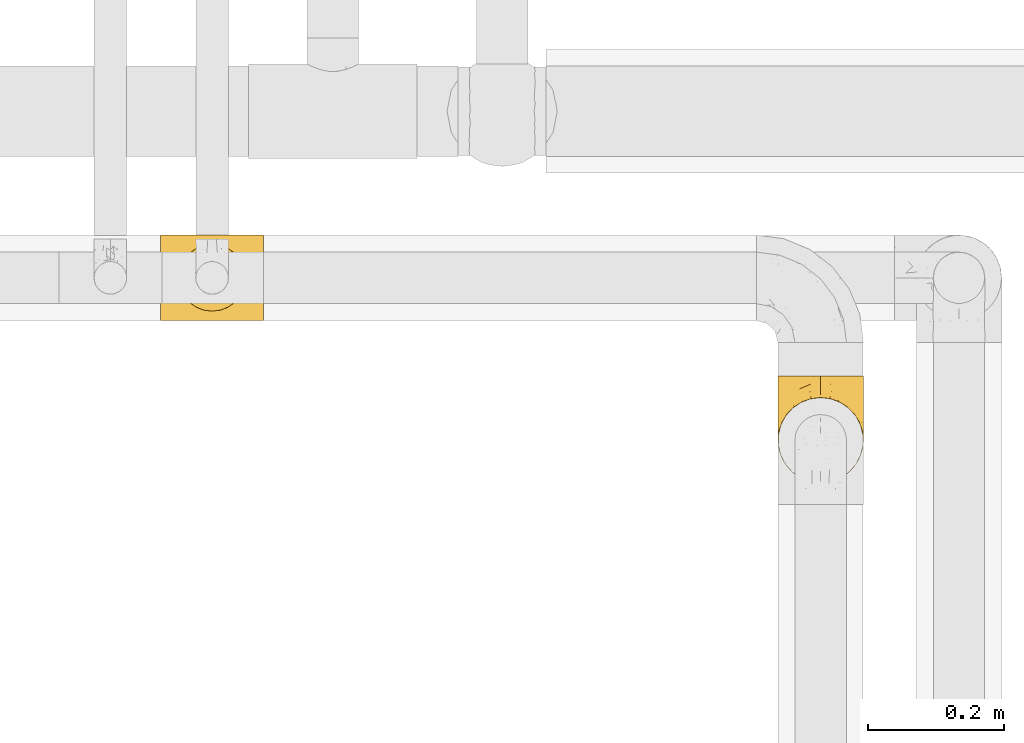
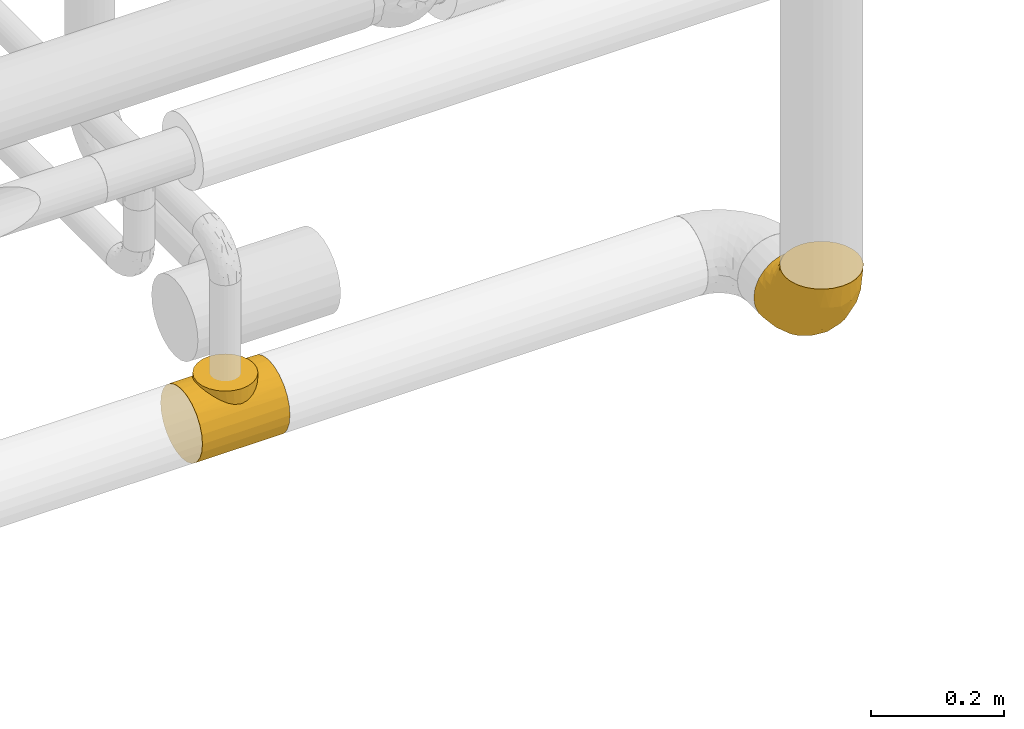
# One storey, part 121 of 827: 2 coverings.
"""IFC2X3 building model written with IfcOpenShell, lengths in millimetres."""

from ifc_helpers import new_model, entity, si_unit, converted_unit, derived_unit, direction, frame, origin, place, context, subcontext, project, spatial, faceted_brep, element, save


model = new_model("IFC2X3")

# Units and contexts
model_context = context("Model", 3, precision=0.01, world=origin(), true_north=direction((6.12303176911189e-17, 1.0)))
body_context = subcontext(model_context, "Body", "Model", "MODEL_VIEW")
ifc_project = project(units=[si_unit("LENGTHUNIT", "METRE", prefix="MILLI"), si_unit("AREAUNIT", "SQUARE_METRE"), si_unit("VOLUMEUNIT", "CUBIC_METRE"), converted_unit("PLANEANGLEUNIT", "DEGREE", entity("IfcRatioMeasure", 0.0174532925199433), si_unit("PLANEANGLEUNIT", "RADIAN"), dimensions=[0, 0, 0, 0, 0, 0, 0]), si_unit("MASSUNIT", "GRAM", prefix="KILO"), derived_unit("MASSDENSITYUNIT", [(si_unit("MASSUNIT", "GRAM", prefix="KILO"), 1), (si_unit("LENGTHUNIT", "METRE"), -3)]), derived_unit("MOMENTOFINERTIAUNIT", [(si_unit("LENGTHUNIT", "METRE"), 4)]), si_unit("TIMEUNIT", "SECOND"), si_unit("FREQUENCYUNIT", "HERTZ"), si_unit("THERMODYNAMICTEMPERATUREUNIT", "DEGREE_CELSIUS"), derived_unit("THERMALTRANSMITTANCEUNIT", [(si_unit("MASSUNIT", "GRAM", prefix="KILO"), 1), (si_unit("THERMODYNAMICTEMPERATUREUNIT", "KELVIN"), -1), (si_unit("TIMEUNIT", "SECOND"), -3)]), derived_unit("VOLUMETRICFLOWRATEUNIT", [(si_unit("LENGTHUNIT", "METRE"), 3), (si_unit("TIMEUNIT", "SECOND"), -1)]), derived_unit("MASSFLOWRATEUNIT", [(si_unit("MASSUNIT", "GRAM", prefix="KILO"), 1), (si_unit("TIMEUNIT", "SECOND"), -1)]), derived_unit("ROTATIONALFREQUENCYUNIT", [(si_unit("TIMEUNIT", "SECOND"), -1)]), si_unit("ELECTRICCURRENTUNIT", "AMPERE"), si_unit("ELECTRICVOLTAGEUNIT", "VOLT"), si_unit("POWERUNIT", "WATT"), si_unit("FORCEUNIT", "NEWTON", prefix="KILO"), si_unit("ILLUMINANCEUNIT", "LUX"), si_unit("LUMINOUSFLUXUNIT", "LUMEN"), si_unit("LUMINOUSINTENSITYUNIT", "CANDELA"), derived_unit("USERDEFINED", [(si_unit("MASSUNIT", "GRAM", prefix="KILO"), -1), (si_unit("LENGTHUNIT", "METRE"), -2), (si_unit("TIMEUNIT", "SECOND"), 3), (si_unit("LUMINOUSFLUXUNIT", "LUMEN"), 1)]), derived_unit("LINEARVELOCITYUNIT", [(si_unit("LENGTHUNIT", "METRE"), 1), (si_unit("TIMEUNIT", "SECOND"), -1)]), si_unit("PRESSUREUNIT", "PASCAL"), derived_unit("USERDEFINED", [(si_unit("LENGTHUNIT", "METRE"), -2), (si_unit("MASSUNIT", "GRAM", prefix="KILO"), 1), (si_unit("TIMEUNIT", "SECOND"), -2)]), derived_unit("LINEARFORCEUNIT", [(si_unit("MASSUNIT", "GRAM", prefix="KILO"), 1), (si_unit("LENGTHUNIT", "METRE"), 1), (si_unit("TIMEUNIT", "SECOND"), -2), (si_unit("LENGTHUNIT", "METRE"), -1)]), derived_unit("PLANARFORCEUNIT", [(si_unit("MASSUNIT", "GRAM", prefix="KILO"), 1), (si_unit("LENGTHUNIT", "METRE"), 1), (si_unit("TIMEUNIT", "SECOND"), -2), (si_unit("LENGTHUNIT", "METRE"), -2)])], contexts=[model_context])

# Site, building, storey
site_placement = place(None, origin())
site = spatial("IfcSite", under=ifc_project, at=site_placement, CompositionType="ELEMENT")
building_placement = place(site_placement, origin())
building = spatial("IfcBuilding", under=site, at=building_placement, CompositionType="ELEMENT")
storey_placement = place(building_placement, frame((0.0, 0.0, 28200.0)))
storey = spatial("IfcBuildingStorey", under=building, at=storey_placement, Name="08", CompositionType="ELEMENT", Elevation=28200.0)

# Coverings
covering_1_placement = place(storey_placement, frame((25690.21, 12005.36, 2535.35)))
element("IfcCovering", 1, at=covering_1_placement, inside=storey, Name=":ADSK_", ObjectType=":ADSK_", PredefinedType="INSULATION", context=body_context, shape_type="Brep", body=[
    faceted_brep([(152.0, 33.12, 10.04), (152.0, 48.33, 3.74), (152.0, 64.65, 1.6), (152.0, 80.96, 3.74), (152.0, 96.17, 10.04), (152.0, 109.23, 20.06), (152.0, 119.25, 33.12), (152.0, 125.55, 48.33), (152.0, 127.7, 64.65), (152.0, 125.55, 80.96), (152.0, 119.25, 96.17), (152.0, 109.23, 109.23), (152.0, 102.7, 114.24), (152.0, 96.17, 119.25), (152.0, 88.57, 122.4), (152.0, 80.96, 125.55), (152.0, 72.8, 126.62), (152.0, 64.65, 127.7), (152.0, 56.49, 126.62), (152.0, 48.33, 125.55), (152.0, 40.72, 122.4), (152.0, 33.12, 119.25), (152.0, 26.59, 114.24), (152.0, 20.06, 109.23), (152.0, 10.04, 96.17), (152.0, 3.74, 80.96), (152.0, 1.6, 64.65), (152.0, 3.74, 48.33), (152.0, 10.04, 33.12), (152.0, 20.06, 20.06), (0.0, 127.7, 64.65), (0.0, 125.55, 48.33), (0.0, 119.25, 33.12), (0.0, 109.23, 20.06), (0.0, 96.17, 10.04), (0.0, 80.96, 3.74), (0.0, 64.65, 1.6), (0.0, 48.33, 3.74), (0.0, 33.12, 10.04), (0.0, 20.06, 20.06), (0.0, 10.04, 33.12), (0.0, 3.74, 48.33), (0.0, 1.6, 64.65), (0.0, 3.74, 80.96), (0.0, 10.04, 96.17), (0.0, 20.06, 109.23), (0.0, 26.59, 114.24), (0.0, 33.12, 119.25), (0.0, 40.72, 122.4), (0.0, 48.33, 125.55), (0.0, 56.49, 126.62), (0.0, 64.65, 127.7), (0.0, 72.8, 126.62), (0.0, 80.96, 125.55), (0.0, 88.57, 122.4), (0.0, 96.17, 119.25), (0.0, 102.7, 114.24), (0.0, 109.23, 109.23), (0.0, 119.25, 96.17), (0.0, 125.55, 80.96), (45.43, 103.13, 114.58), (54.33, 108.76, 109.69), (37.94, 95.74, 119.49), (119.94, 86.67, 123.72), (64.61, 112.46, 105.75), (76.0, 113.8, 104.14), (87.39, 112.46, 105.75), (124.47, 70.38, 127.17), (125.15, 64.65, 127.7), (26.85, 64.65, 127.7), (27.53, 70.38, 127.17), (106.57, 103.13, 114.58), (97.67, 108.76, 109.69), (114.06, 95.74, 119.49), (32.06, 86.67, 123.72), (121.87, 81.39, 125.18), (123.79, 76.12, 126.64), (28.21, 76.12, 126.64), (30.13, 81.39, 125.18), (27.53, 58.91, 127.17), (28.21, 53.17, 126.64), (37.94, 33.55, 119.49), (32.06, 42.62, 123.72), (30.13, 47.9, 125.18), (123.79, 53.17, 126.64), (124.47, 58.91, 127.17), (114.06, 33.55, 119.49), (119.94, 42.62, 123.72), (106.57, 26.16, 114.58), (121.87, 47.9, 125.18), (45.43, 26.16, 114.58), (54.33, 20.53, 109.69), (64.61, 16.83, 105.75), (76.0, 15.5, 104.14), (97.67, 20.53, 109.69), (87.39, 16.83, 105.75), (63.28, 112.12, 131.65), (51.42, 107.21, 131.65), (41.25, 99.4, 131.65), (33.43, 89.22, 131.65), (30.98, 83.29, 131.65), (28.52, 77.37, 131.65), (27.69, 71.01, 131.65), (26.85, 64.65, 131.65), (27.69, 58.28, 131.65), (28.52, 51.92, 131.65), (30.98, 46.0, 131.65), (33.43, 40.07, 131.65), (41.25, 29.89, 131.65), (51.42, 22.08, 131.65), (63.28, 17.17, 131.65), (76.0, 15.5, 131.65), (88.72, 17.17, 131.65), (100.57, 22.08, 131.65), (110.75, 29.89, 131.65), (118.57, 40.07, 131.65), (121.02, 46.0, 131.65), (123.48, 51.92, 131.65), (124.31, 58.28, 131.65), (125.15, 64.65, 131.65), (124.31, 71.01, 131.65), (123.48, 77.37, 131.65), (121.02, 83.29, 131.65), (118.57, 89.22, 131.65), (110.75, 99.4, 131.65), (100.57, 107.21, 131.65), (88.72, 112.12, 131.65), (76.0, 113.8, 131.65)], [[[0, 1, 2, 3, 4, 5, 6, 7, 8, 9, 10, 11, 12, 13, 14, 15, 16, 17, 18, 19, 20, 21, 22, 23, 24, 25, 26, 27, 28, 29]], [[30, 31, 32, 33, 34, 35, 36, 37, 38, 39, 40, 41, 42, 43, 44, 45, 46, 47, 48, 49, 50, 51, 52, 53, 54, 55, 56, 57, 58, 59]], [[34, 33, 5, 4]], [[2, 36, 35, 3]], [[4, 3, 35, 34]], [[6, 32, 31, 7]], [[7, 31, 30, 8]], [[5, 33, 32, 6]], [[59, 9, 8, 30]], [[58, 10, 9, 59]], [[57, 60, 61]], [[56, 55, 62]], [[63, 15, 14]], [[61, 64, 57]], [[60, 57, 56]], [[57, 64, 58]], [[64, 65, 58]], [[66, 11, 10]], [[17, 67, 68]], [[69, 70, 51]], [[71, 11, 72]], [[72, 11, 66]], [[73, 12, 71]], [[66, 10, 65]], [[65, 10, 58]], [[62, 54, 74]], [[54, 62, 55]], [[74, 54, 53]], [[15, 63, 75, 76]], [[77, 53, 52]], [[51, 70, 52]], [[77, 52, 70]], [[53, 77, 78, 74]], [[73, 13, 12]], [[73, 14, 13]], [[14, 73, 63]], [[16, 76, 67]], [[71, 12, 11]], [[17, 16, 67]], [[16, 15, 76]], [[60, 56, 62]], [[50, 79, 51]], [[80, 50, 49]], [[47, 81, 48]], [[82, 48, 81]], [[82, 49, 48]], [[49, 82, 83, 80]], [[50, 80, 79]], [[84, 18, 85]], [[85, 17, 68]], [[51, 79, 69]], [[86, 21, 20]], [[17, 85, 18]], [[20, 19, 87]], [[86, 88, 22]], [[87, 19, 84, 89]], [[81, 46, 90]], [[81, 47, 46]], [[90, 45, 91]], [[45, 90, 46]], [[91, 45, 92]], [[24, 44, 43, 25]], [[93, 92, 44]], [[44, 92, 45]], [[43, 42, 26, 25]], [[84, 19, 18]], [[94, 95, 23]], [[86, 20, 87]], [[22, 21, 86]], [[23, 88, 94]], [[95, 24, 23]], [[93, 24, 95]], [[93, 44, 24]], [[88, 23, 22]], [[27, 41, 40, 28]], [[28, 40, 39, 29]], [[42, 41, 27, 26]], [[0, 38, 37, 1]], [[1, 37, 36, 2]], [[29, 39, 38, 0]], [[96, 97, 98, 99, 100, 101, 102, 103, 104, 105, 106, 107, 108, 109, 110, 111, 112, 113, 114, 115, 116, 117, 118, 119, 120, 121, 122, 123, 124, 125, 126, 127]], [[77, 102, 101]], [[74, 100, 99]], [[103, 70, 69]], [[103, 102, 70]], [[101, 78, 77]], [[62, 74, 99]], [[100, 78, 101]], [[100, 74, 78]], [[99, 98, 62]], [[60, 98, 97]], [[96, 127, 64]], [[102, 77, 70]], [[61, 97, 96]], [[60, 97, 61]], [[64, 61, 96]], [[65, 64, 127]], [[98, 60, 62]], [[66, 127, 126]], [[72, 126, 125]], [[65, 127, 66]], [[119, 67, 120]], [[66, 126, 72]], [[125, 71, 72]], [[125, 124, 71]], [[73, 124, 123]], [[76, 75, 121]], [[67, 119, 68]], [[76, 121, 120]], [[63, 73, 123]], [[63, 123, 122]], [[76, 120, 67]], [[122, 75, 63]], [[121, 75, 122]], [[124, 73, 71]], [[84, 118, 117]], [[87, 116, 115]], [[119, 85, 68]], [[119, 118, 85]], [[117, 89, 84]], [[86, 87, 115]], [[116, 89, 117]], [[118, 84, 85]], [[115, 114, 86]], [[88, 114, 113]], [[113, 112, 94]], [[111, 95, 112]], [[116, 87, 89]], [[88, 113, 94]], [[95, 94, 112]], [[93, 95, 111]], [[114, 88, 86]], [[92, 111, 110]], [[91, 110, 109]], [[93, 111, 92]], [[103, 79, 104]], [[92, 110, 91]], [[109, 90, 91]], [[109, 108, 90]], [[81, 108, 107]], [[80, 83, 105]], [[79, 103, 69]], [[80, 105, 104]], [[82, 81, 107]], [[82, 107, 106]], [[80, 104, 79]], [[106, 83, 82]], [[105, 83, 106]], [[108, 81, 90]]]),
])
covering_2_placement = place(storey_placement, frame((26598.99, 11765.81, 2535.35)))
element("IfcCovering", 2, at=covering_2_placement, inside=storey, Name=":ADSK_", ObjectType=":ADSK_", PredefinedType="INSULATION", context=body_context, shape_type="Brep", body=[
    faceted_brep([(3.18, 50.62, 159.65), (7.84, 37.29, 159.65), (15.35, 25.34, 159.65), (25.33, 15.35, 159.65), (37.29, 7.84, 159.65), (50.61, 3.18, 159.65), (64.65, 1.6, 159.65), (78.67, 3.18, 159.65), (92.0, 7.84, 159.65), (103.95, 15.35, 159.65), (113.94, 25.33, 159.65), (121.45, 37.29, 159.65), (126.11, 50.61, 159.65), (127.7, 64.65, 159.65), (126.11, 78.67, 159.65), (121.45, 92.0, 159.65), (113.94, 103.95, 159.65), (103.96, 113.94, 159.65), (92.0, 121.45, 159.65), (78.68, 126.11, 159.65), (64.65, 127.7, 159.65), (50.62, 126.11, 159.65), (37.29, 121.45, 159.65), (25.34, 113.94, 159.65), (15.35, 103.96, 159.65), (7.84, 92.0, 159.65), (3.18, 78.68, 159.65), (1.6, 64.65, 159.65), (64.65, 159.65, 127.7), (80.96, 159.65, 125.55), (96.17, 159.65, 119.25), (109.23, 159.65, 109.23), (119.25, 159.65, 96.17), (125.55, 159.65, 80.96), (126.29, 159.65, 75.35), (127.7, 159.65, 64.65), (125.55, 159.65, 48.33), (119.25, 159.65, 33.12), (109.23, 159.65, 20.06), (96.17, 159.65, 10.04), (80.96, 159.65, 3.74), (64.65, 159.65, 1.6), (48.33, 159.65, 3.74), (33.12, 159.65, 10.04), (20.06, 159.65, 20.06), (10.04, 159.65, 33.12), (3.74, 159.65, 48.33), (1.6, 159.65, 64.65), (3.01, 159.65, 75.35), (3.74, 159.65, 80.96), (10.04, 159.65, 96.17), (20.06, 159.65, 109.23), (33.12, 159.65, 119.25), (48.33, 159.65, 125.55), (28.19, 131.11, 16.01), (42.57, 121.84, 10.29), (30.59, 98.59, 24.76), (53.36, 132.73, 4.94), (64.65, 118.74, 6.98), (15.9, 45.67, 87.32), (18.23, 62.3, 62.3), (32.42, 49.95, 58.52), (45.22, 65.74, 36.35), (64.65, 80.62, 22.77), (64.65, 47.89, 47.89), (9.73, 117.53, 40.91), (16.54, 90.48, 42.82), (6.44, 98.53, 57.25), (4.21, 128.08, 51.19), (2.65, 107.83, 66.64), (23.51, 30.59, 98.56), (35.48, 23.56, 94.44), (33.22, 14.41, 123.53), (42.18, 94.66, 20.12), (53.52, 103.54, 12.95), (17.3, 121.36, 28.48), (64.65, 6.98, 118.74), (45.71, 9.17, 121.88), (48.33, 35.7, 65.08), (50.95, 18.43, 92.08), (6.44, 57.25, 98.53), (3.41, 81.84, 81.84), (8.33, 72.43, 72.43), (2.62, 56.38, 134.31), (6.65, 43.86, 129.11), (1.6, 103.81, 82.79), (1.6, 117.05, 76.04), (1.6, 130.29, 69.29), (22.17, 21.28, 129.58), (14.22, 34.21, 115.86), (26.48, 74.07, 42.36), (1.6, 82.79, 103.81), (1.6, 88.04, 98.55), (1.6, 93.3, 93.3), (1.6, 66.61, 147.25), (1.6, 67.95, 138.77), (1.6, 69.29, 130.29), (2.65, 66.64, 107.83), (1.6, 76.04, 117.05), (64.65, 22.77, 80.62), (1.6, 147.25, 66.61), (16.24, 120.78, 121.29), (27.48, 128.88, 128.09), (20.83, 132.53, 118.04), (3.08, 145.71, 79.47), (6.64, 132.18, 94.94), (2.74, 121.21, 86.01), (3.84, 115.88, 94.69), (3.28, 134.78, 83.06), (5.99, 113.68, 104.39), (10.3, 124.96, 107.01), (15.78, 105.67, 148.3), (24.69, 116.22, 143.82), (11.25, 103.69, 134.19), (27.69, 149.68, 116.87), (19.31, 142.04, 111.58), (37.19, 151.17, 122.36), (33.01, 140.2, 124.16), (8.24, 145.72, 94.28), (49.89, 147.4, 128.25), (50.1, 128.57, 146.72), (48.9, 136.38, 134.92), (36.15, 126.93, 138.87), (2.54, 79.77, 133.28), (3.58, 89.98, 121.77), (3.12, 79.6, 145.83), (64.65, 131.98, 143.67), (6.01, 90.59, 139.93), (64.65, 129.31, 153.63), (37.71, 133.25, 132.32), (22.19, 119.53, 132.59), (13.01, 111.1, 126.42), (12.97, 143.67, 102.97), (38.95, 123.62, 149.52), (6.55, 100.76, 120.88), (64.65, 143.67, 131.98), (2.52, 104.28, 96.12), (9.45, 112.26, 115.84), (4.58, 103.95, 108.2), (2.83, 92.99, 110.85), (92.1, 151.17, 122.36), (101.63, 144.66, 118.35), (79.39, 147.4, 128.25), (127.7, 147.25, 66.61), (79.2, 128.57, 146.72), (80.4, 136.38, 134.92), (126.41, 93.43, 110.73), (122.74, 100.15, 121.83), (125.71, 89.98, 121.77), (127.7, 103.81, 82.79), (127.7, 117.05, 76.04), (126.55, 121.21, 86.01), (118.04, 103.69, 134.19), (117.36, 110.23, 124.9), (108.2, 118.45, 132.35), (126.01, 134.78, 83.06), (122.65, 132.18, 94.94), (116.32, 143.67, 102.97), (109.98, 142.04, 111.58), (113.06, 120.78, 121.29), (107.85, 132.4, 118.82), (102.33, 127.76, 128.68), (121.05, 145.72, 94.28), (126.21, 145.71, 79.47), (118.99, 124.96, 107.01), (90.34, 123.62, 149.51), (96.28, 140.2, 124.16), (127.7, 66.61, 147.25), (127.7, 67.95, 138.77), (93.14, 126.93, 138.87), (104.6, 116.21, 143.82), (123.28, 90.59, 139.92), (126.75, 79.77, 133.28), (113.51, 105.66, 148.3), (127.7, 69.29, 130.29), (126.17, 79.6, 145.83), (91.96, 133.38, 131.94), (127.7, 82.79, 103.81), (127.7, 76.04, 117.05), (126.77, 104.28, 96.12), (125.45, 115.88, 94.69), (123.3, 113.68, 104.39), (119.94, 112.97, 114.83), (127.7, 93.3, 93.3), (124.71, 103.94, 108.2), (127.7, 130.29, 69.29), (98.7, 98.59, 24.76), (101.1, 131.11, 16.01), (111.99, 121.36, 28.48), (119.56, 117.53, 40.91), (86.72, 121.84, 10.29), (75.78, 105.45, 12.23), (75.87, 132.83, 4.91), (126.64, 107.83, 66.64), (126.67, 56.38, 134.31), (122.63, 43.85, 129.11), (122.85, 57.25, 98.53), (80.96, 35.7, 65.08), (96.87, 49.95, 58.52), (93.81, 23.55, 94.45), (126.64, 66.64, 107.83), (125.88, 81.84, 81.84), (125.08, 128.08, 51.19), (86.22, 92.46, 20.8), (105.77, 30.58, 98.56), (107.12, 21.27, 129.58), (96.19, 12.64, 131.93), (113.39, 45.66, 87.32), (115.06, 34.21, 115.86), (112.75, 90.48, 42.82), (84.07, 65.74, 36.35), (122.85, 98.53, 57.25), (120.97, 72.43, 72.43), (111.06, 62.3, 62.3), (96.3, 72.15, 38.39), (75.94, 82.52, 22.86), (80.53, 19.03, 92.06), (83.57, 9.17, 121.88)], [[[0, 1, 2, 3, 4, 5, 6, 7, 8, 9, 10, 11, 12, 13, 14, 15, 16, 17, 18, 19, 20, 21, 22, 23, 24, 25, 26, 27]], [[28, 29, 30, 31, 32, 33, 34, 35, 36, 37, 38, 39, 40, 41, 42, 43, 44, 45, 46, 47, 48, 49, 50, 51, 52, 53]], [[54, 55, 56]], [[57, 41, 58]], [[59, 60, 61]], [[62, 63, 64]], [[65, 66, 67]], [[68, 67, 69]], [[70, 71, 72]], [[55, 73, 56]], [[43, 42, 55]], [[55, 74, 73]], [[44, 75, 45]], [[44, 43, 54]], [[76, 5, 77]], [[71, 78, 79]], [[45, 75, 65]], [[46, 68, 47]], [[80, 81, 82]], [[0, 83, 84]], [[69, 85, 86, 87]], [[69, 81, 85]], [[84, 1, 0]], [[2, 88, 3]], [[4, 3, 72]], [[44, 54, 75]], [[5, 4, 77]], [[89, 2, 1]], [[72, 3, 88]], [[5, 76, 6]], [[70, 88, 89]], [[68, 65, 67]], [[88, 2, 89]], [[56, 90, 66]], [[64, 78, 62]], [[81, 91, 92, 93, 85]], [[83, 27, 94, 95, 96]], [[62, 61, 90]], [[97, 96, 98, 91]], [[80, 97, 81]], [[42, 57, 55]], [[62, 78, 61]], [[84, 89, 1]], [[78, 64, 99]], [[57, 74, 55]], [[76, 77, 79]], [[77, 72, 71]], [[82, 81, 67]], [[97, 83, 96]], [[80, 89, 84]], [[79, 78, 99]], [[71, 70, 61]], [[81, 97, 91]], [[83, 80, 84]], [[68, 87, 100, 47]], [[81, 69, 67]], [[68, 69, 87]], [[65, 46, 45]], [[65, 68, 46]], [[66, 65, 75]], [[56, 66, 75]], [[66, 60, 82]], [[71, 61, 78]], [[60, 66, 90]], [[83, 97, 80]], [[27, 83, 0]], [[59, 70, 89]], [[70, 59, 61]], [[89, 80, 59]], [[82, 59, 80]], [[55, 54, 43]], [[75, 54, 56]], [[66, 82, 67]], [[59, 82, 60]], [[41, 57, 42]], [[74, 57, 58]], [[58, 63, 74]], [[62, 74, 63]], [[74, 62, 73]], [[62, 56, 73]], [[4, 72, 77]], [[70, 72, 88]], [[76, 79, 99]], [[71, 79, 77]], [[62, 90, 56]], [[60, 90, 61]], [[101, 102, 103]], [[100, 87, 104]], [[105, 106, 107]], [[108, 104, 87]], [[107, 109, 110]], [[108, 87, 86]], [[111, 112, 113]], [[114, 51, 115]], [[116, 114, 117]], [[51, 50, 118]], [[119, 28, 53]], [[120, 121, 122]], [[98, 123, 124]], [[125, 96, 95]], [[116, 53, 52]], [[126, 121, 120]], [[104, 108, 118]], [[98, 124, 91]], [[25, 24, 127]], [[120, 128, 126]], [[122, 129, 102]], [[95, 94, 27, 26]], [[122, 102, 130]], [[125, 127, 123]], [[24, 111, 127]], [[21, 20, 128]], [[112, 130, 131]], [[48, 47, 100, 49]], [[132, 110, 115]], [[23, 111, 24]], [[129, 119, 117]], [[120, 133, 21]], [[112, 23, 22]], [[134, 113, 131]], [[121, 126, 135]], [[133, 112, 22]], [[128, 120, 21]], [[132, 51, 118]], [[120, 122, 133]], [[119, 121, 135]], [[129, 117, 102]], [[125, 26, 25]], [[26, 125, 95]], [[127, 125, 25]], [[28, 119, 135]], [[119, 53, 116]], [[127, 113, 124]], [[96, 125, 123]], [[112, 131, 113]], [[101, 103, 110]], [[85, 93, 136]], [[124, 123, 127]], [[98, 96, 123]], [[112, 111, 23]], [[127, 111, 113]], [[112, 133, 122]], [[21, 133, 22]], [[107, 110, 105]], [[110, 109, 137]], [[86, 106, 108]], [[138, 109, 136]], [[105, 118, 108]], [[107, 106, 85]], [[104, 50, 49]], [[124, 134, 139]], [[138, 93, 92]], [[92, 91, 139]], [[100, 104, 49]], [[118, 105, 132]], [[104, 118, 50]], [[110, 132, 105]], [[51, 132, 115]], [[108, 106, 105]], [[85, 106, 86]], [[114, 116, 52]], [[119, 116, 117]], [[51, 114, 52]], [[114, 115, 103]], [[117, 114, 103]], [[130, 102, 101]], [[117, 103, 102]], [[110, 103, 115]], [[130, 101, 131]], [[122, 130, 112]], [[101, 137, 131]], [[113, 134, 124]], [[137, 134, 131]], [[124, 139, 91]], [[134, 138, 139]], [[92, 139, 138]], [[110, 137, 101]], [[134, 137, 138]], [[136, 109, 107]], [[137, 109, 138]], [[85, 136, 107]], [[138, 136, 93]], [[122, 121, 129]], [[129, 121, 119]], [[30, 140, 141]], [[30, 29, 140]], [[28, 135, 142]], [[143, 35, 34, 33]], [[19, 144, 128]], [[126, 145, 135]], [[146, 147, 148]], [[149, 150, 151]], [[152, 153, 154]], [[155, 156, 151]], [[157, 31, 158]], [[159, 160, 161]], [[32, 162, 163]], [[158, 31, 30]], [[157, 164, 156]], [[126, 144, 145]], [[126, 128, 144]], [[18, 165, 19]], [[141, 166, 160]], [[14, 13, 167, 168]], [[163, 143, 33]], [[169, 165, 170]], [[18, 17, 170]], [[153, 159, 154]], [[142, 135, 145]], [[148, 171, 172]], [[159, 161, 154]], [[171, 152, 173]], [[173, 17, 16]], [[16, 15, 171]], [[158, 160, 164]], [[174, 175, 168]], [[173, 170, 17]], [[19, 128, 20]], [[174, 172, 175]], [[165, 169, 144]], [[162, 157, 156]], [[175, 172, 171]], [[144, 169, 145]], [[176, 169, 161]], [[166, 140, 142]], [[175, 171, 15]], [[168, 175, 14]], [[14, 175, 15]], [[142, 145, 176]], [[28, 142, 29]], [[148, 177, 146]], [[148, 178, 177]], [[152, 171, 148]], [[179, 180, 181]], [[164, 180, 156]], [[174, 178, 172]], [[148, 172, 178]], [[171, 173, 16]], [[170, 173, 152]], [[19, 165, 144]], [[170, 165, 18]], [[153, 182, 159]], [[146, 183, 184]], [[181, 180, 164]], [[180, 151, 156]], [[163, 155, 185]], [[155, 150, 185]], [[162, 156, 155]], [[143, 163, 185]], [[180, 179, 149]], [[32, 163, 33]], [[163, 162, 155]], [[31, 162, 32]], [[31, 157, 162]], [[164, 157, 158]], [[149, 151, 180]], [[155, 151, 150]], [[142, 140, 29]], [[141, 140, 166]], [[176, 145, 169]], [[30, 141, 158]], [[164, 160, 159]], [[158, 141, 160]], [[166, 161, 160]], [[154, 169, 170]], [[169, 154, 161]], [[152, 154, 170]], [[147, 152, 148]], [[153, 147, 182]], [[181, 182, 184]], [[164, 159, 182]], [[161, 166, 176]], [[142, 176, 166]], [[183, 146, 177]], [[184, 182, 147]], [[184, 147, 146]], [[152, 147, 153]], [[182, 181, 164]], [[179, 184, 183]], [[184, 179, 181]], [[149, 179, 183]], [[186, 187, 188]], [[37, 36, 189]], [[190, 191, 192]], [[193, 185, 150, 149]], [[194, 195, 196]], [[197, 198, 199]], [[200, 201, 177]], [[193, 202, 185]], [[203, 190, 186]], [[202, 189, 36]], [[41, 40, 192]], [[204, 205, 199]], [[9, 8, 206]], [[187, 190, 39]], [[40, 39, 190]], [[38, 37, 188]], [[207, 208, 204]], [[202, 35, 143, 185]], [[39, 38, 187]], [[195, 11, 208]], [[201, 149, 183, 177]], [[188, 189, 209]], [[197, 64, 210]], [[186, 188, 209]], [[13, 12, 194]], [[211, 201, 212]], [[12, 11, 195]], [[193, 201, 211]], [[212, 201, 196]], [[10, 208, 11]], [[213, 214, 209]], [[64, 63, 215]], [[216, 197, 199]], [[8, 217, 206]], [[7, 217, 8]], [[203, 191, 190]], [[7, 6, 76]], [[208, 205, 204]], [[205, 10, 9]], [[199, 205, 206]], [[7, 76, 217]], [[205, 208, 10]], [[216, 76, 99]], [[200, 177, 178, 174]], [[64, 197, 99]], [[63, 58, 191]], [[208, 196, 195]], [[196, 200, 194]], [[198, 197, 210]], [[216, 199, 217]], [[201, 193, 149]], [[202, 193, 211]], [[202, 211, 189]], [[35, 202, 36]], [[211, 212, 209]], [[37, 189, 188]], [[211, 209, 189]], [[213, 198, 214]], [[200, 174, 194]], [[201, 200, 196]], [[214, 198, 210]], [[213, 207, 198]], [[194, 174, 168, 167, 13]], [[195, 194, 12]], [[198, 204, 199]], [[204, 198, 207]], [[212, 207, 213]], [[196, 208, 207]], [[188, 187, 38]], [[190, 187, 186]], [[207, 212, 196]], [[209, 212, 213]], [[214, 203, 186]], [[191, 215, 63]], [[191, 203, 215]], [[192, 191, 58]], [[41, 192, 58]], [[190, 192, 40]], [[203, 210, 215]], [[64, 215, 210]], [[199, 206, 217]], [[9, 206, 205]], [[76, 216, 217]], [[99, 197, 216]], [[203, 214, 210]], [[209, 214, 186]]]),
])

save(model, "model.ifc")
